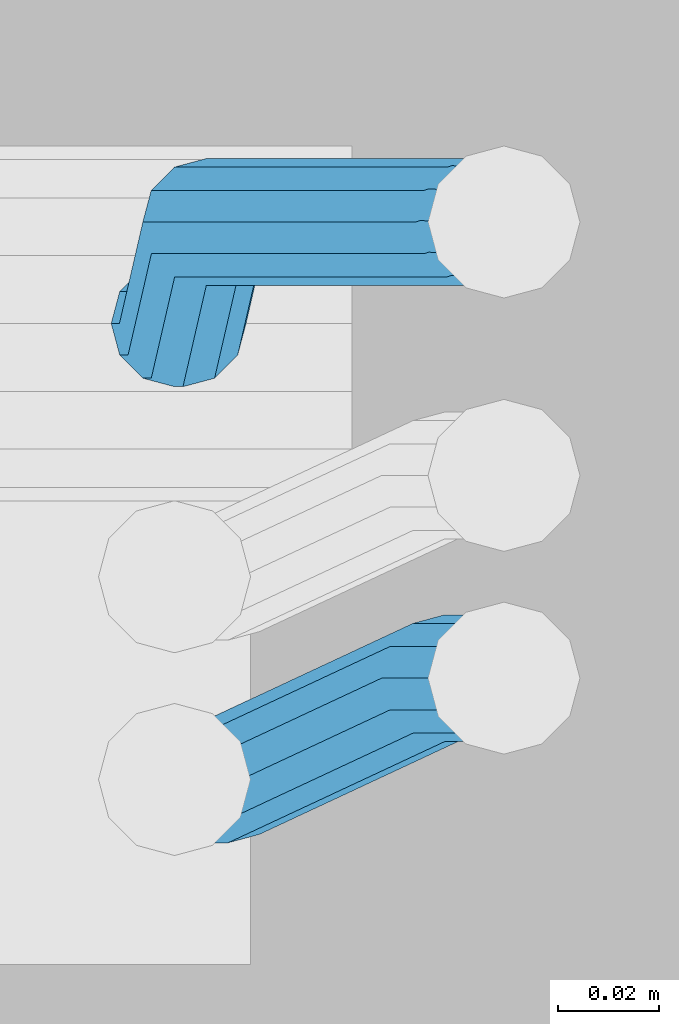
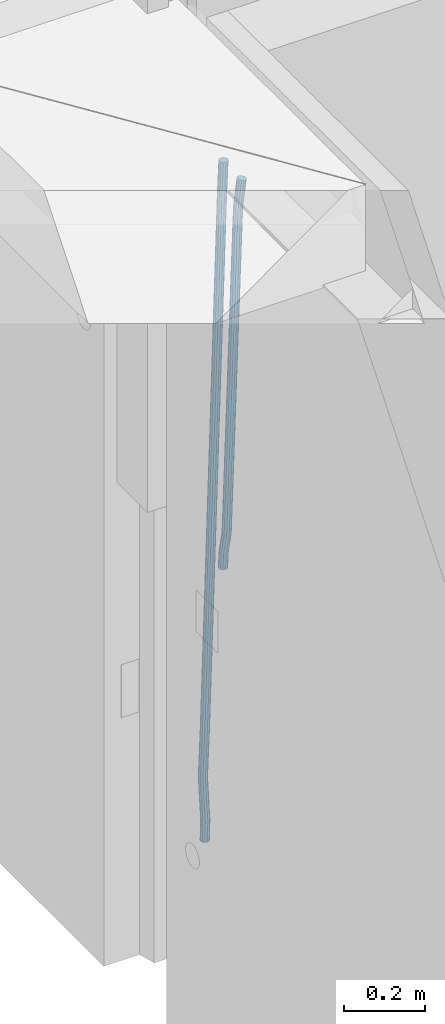
# One storey, part 117 of 341: 2 beams, 1 element without a shape of its own.
"""IFC2X3 building model written with IfcOpenShell, lengths in millimetres."""

from ifc_helpers import new_model, si_unit, frame, origin_with_axes, place, context, subcontext, project, spatial, faceted_brep, material, type_object, element, aggregate, save


model = new_model("IFC2X3")

# Units and contexts
model_context = context("Model", 3, precision=1e-05, world=origin_with_axes())
body_context = subcontext(model_context, "Body", "Model", "MODEL_VIEW")
ifc_project = project(units=[si_unit("LENGTHUNIT", "METRE", prefix="MILLI"), si_unit("AREAUNIT", "SQUARE_METRE"), si_unit("VOLUMEUNIT", "CUBIC_METRE"), si_unit("MASSUNIT", "GRAM", prefix="KILO"), si_unit("TIMEUNIT", "SECOND"), si_unit("PLANEANGLEUNIT", "RADIAN"), si_unit("SOLIDANGLEUNIT", "STERADIAN"), si_unit("THERMODYNAMICTEMPERATUREUNIT", "DEGREE_CELSIUS"), si_unit("LUMINOUSINTENSITYUNIT", "LUMEN")], contexts=[model_context])

# Site, building, storey
site_placement = place(None, origin_with_axes())
site = spatial("IfcSite", under=ifc_project, at=site_placement, CompositionType="ELEMENT")
building_placement = place(site_placement, origin_with_axes())
building = spatial("IfcBuilding", under=site, at=building_placement, CompositionType="ELEMENT")
storey_placement = place(building_placement, origin_with_axes())
storey = spatial("IfcBuildingStorey", under=building, at=storey_placement, Name="5", CompositionType="ELEMENT", Elevation=0.0)

# Assembly, beams
assembly_placement = place(storey_placement, origin_with_axes())
assembly = element("IfcElementAssembly", 1, at=assembly_placement, inside=storey, AssemblyPlace="NOTDEFINED", PredefinedType="REINFORCEMENT_UNIT")
ifc_material = material()
beam_type = type_object("IfcBeamType", Name="D25", PredefinedType="NOTDEFINED")
beam_1_placement = place(assembly_placement, frame((17644.9989431251, 20116.4982803956, 95267.5035525011), z_axis=(0.0, 1.0, 0.0), x_axis=(0.0467115440025518, 0.0, 0.998908420055061)))
beam_1 = element("IfcBeam", 2, at=beam_1_placement, type_object=beam_type, material=ifc_material, Name="JM25", ObjectType="D25", context=body_context, shape_type="Brep", body=[
    faceted_brep([(-7.41420080885291e-08, -12.5, -3.63797880709171e-12), (-6.42030499875546e-08, -10.8253175473074, -6.25000000000364), (48.7743672639481, -10.8253174221936, -6.25), (48.7743672682554, -12.4999998748863, 0.0), (-3.70782800018787e-08, -6.25000000000364, -10.8253175473074), (48.7743672522192, -6.24999987488263, -10.8253175473037), (-1.45519152283669e-11, -3.63797880709171e-12, -12.5), (48.7743672361976, 1.25113729154691e-07, -12.5), (3.70637280866504e-08, 6.25, -10.8253175473074), (48.7743672201614, 6.25000012511737, -10.8253175473037), (6.42030499875546e-08, 10.8253175473001, -6.25000000000364), (48.774367208418, 10.8253176724174, -6.25), (7.41420080885291e-08, 12.4999999999927, 0.0), (48.7743672041252, 12.5000001251174, 0.0), (6.42176019027829e-08, 10.8253175473001, 6.24999999999636), (48.774367208418, 10.8253176724174, 6.25), (3.70928319171071e-08, 6.24999999999636, 10.8253175473037), (48.7743672201614, 6.25000012511737, 10.8253175473037), (1.45519152283669e-11, -3.63797880709171e-12, 12.4999999999964), (48.7743672361976, 1.25113729154691e-07, 12.5), (-3.7049176171422e-08, -6.25000000000364, 10.8253175473001), (48.7743672522192, -6.24999987488263, 10.8253175473037), (-6.41884980723262e-08, -10.8253175473074, 6.25), (48.7743672639481, -10.8253174221936, 6.25), (50.6284132863948, -10.8253174174351, -6.25), (50.7256294211547, -12.4999998698804, 0.0), (50.362813866901, -6.2499998708081, -10.8253175473037), (49.9999983126327, 1.28262399812229e-07, -12.5), (49.6371827583935, 6.25000012732926, -10.8253175473037), (49.3715833388851, 10.8253176739527, -6.25), (49.2743672041252, 12.5000001264016, 0.0), (49.3715833388851, 10.8253176739527, 6.25), (49.6371827583935, 6.25000012732926, 10.8253175473037), (49.9999983126327, 1.28262399812229e-07, 12.5), (50.362813866901, -6.2499998708081, 10.8253175473037), (50.6284132863948, -10.8253174174351, 6.25), (52.4700055286376, -10.6107838149001, -6.25), (52.6637847850943, -12.2742172873113, 0.0), (51.9405907545442, -6.0661990532717, -10.8253175473037), (51.2173967239651, 0.141819180764287, -12.5), (50.494202693415, 6.34983741480755, -10.8253175473037), (49.9647879192926, 10.8944221764359, -6.25), (49.7710086628358, 12.5578556488472, 0.0), (49.9647879192926, 10.8944221764359, 6.25), (50.494202693415, 6.34983741480755, 10.8253175473037), (51.2173967239651, 0.141819180764287, 12.5), (51.9405907545442, -6.0661990532717, 10.8253175473037), (52.4700055286376, -10.6107838149037, 6.25), (100.1682419055, -5.05424733003747, -6.25), (100.362021161956, -6.71768080244692, 0.0), (99.6388271314063, -0.509662568409112, -10.8253175473037), (98.9156331008271, 5.69835566563052, -12.5), (98.192439070277, 11.9063738996665, -10.8253175473037), (97.6630242961546, 16.4509586612985, -6.25), (97.4692450396979, 18.1143921337098, 0.0), (97.6630242961546, 16.4509586612985, 6.25), (98.192439070277, 11.9063738996665, 10.8253175473037), (98.9156331008271, 5.69835566563052, 12.5), (99.6388271314063, -0.509662568409112, 10.8253175473037), (100.1682419055, -5.05424733003747, 6.25), (100.829389846811, -4.97722786481609, -6.25), (100.858662620667, -6.65982528000313, 0.0), (100.613505361369, -0.39611884945225, -10.8253175473037), (100.268855237926, 5.8559973049887, -12.5), (99.8877881987282, 12.1038711239344, -10.8253175473037), (99.5724108491268, 16.6733898631865, -6.25), (99.4072282953421, 18.3401546667665, 0.0), (99.4365010692127, 16.6575572515831, 6.25), (99.6523855546402, 12.0764482362174, 10.8253175473037), (99.9970356780832, 5.82433208178009, 12.5), (100.37810271731, -0.423541737165579, 10.8253175473037), (100.693480066882, -4.99306047642312, 6.25), (101.494850382805, -4.9772278650471, -6.23547852116099), (101.358543616545, -6.65982528017412, 0.0109082521194068), (101.594541309358, -0.396118849792401, -10.8039096771354), (101.63090429295, 5.85599730451395, -12.4702777768798), (101.594195901474, 12.1038711233377, -10.7880808337759), (101.49425211882, 16.6733898625134, -6.2080621602363), (101.357852800793, 18.340154666088, 0.0425659388420172), (101.221546034547, 16.6575572509591, 6.28895271212241), (101.121855107995, 12.0764482357044, 10.8573838680968), (101.085492124403, 5.82433208139992, 12.5237519678412), (101.122200515863, -0.423541737425694, 10.8415550247373), (101.222144298532, -4.99306047660866, 6.26153635119772), (1016.15234243186, -4.97722818425427, 13.7239010304511), (1016.01603566563, -6.65982559938311, 19.9702878037351), (1016.25203335841, -0.396119168995938, 9.15546987447669), (1016.28839634202, 5.85599698530859, 7.48910177473226), (1016.25168795056, 12.1038708041378, 9.17129871783618), (1016.15174416787, 16.6733895433135, 13.7513173913758), (1016.01534484986, 18.3401543468826, 20.0019454904541), (1015.8790380836, 16.6575569317556, 26.2483322637381), (1015.77934715705, 12.0764479165045, 30.8167634197125), (1015.74298417347, 5.82433176219456, 32.4831315194569), (1015.77969256493, -0.423542056632868, 30.8009345763494), (1015.8796363476, -4.99306079580856, 26.2209159028134), (1016.72024271244, -4.97722818445254, 13.7362935788587), (1016.65208128402, -6.65982559960139, 19.984167399125), (1016.77009392806, -0.396119169179656, 9.16677483576495), (1016.7882773379, 5.85599698513579, 7.50001002685531), (1016.76992071191, 12.1038708039559, 9.18260743664359), (1016.71994269331, 16.6733895431171, 13.7637164479929), (1016.65173485172, 18.3401543466607, 20.015832600875), (1016.58357342328, 16.65755693151, 26.2637064211413), (1016.53372220766, 12.0764479162353, 30.833225164235), (1016.51553879784, 5.82433176192717, 32.4999899731447), (1016.53389542381, -0.423542056894803, 30.8173925633564), (1016.58387344243, -4.99306079605594, 26.2362835520071), (1017.28827819017, -4.97722813975997, 13.7362935788587), (1017.28827832255, -6.6598255495519, 19.984167399125), (1017.28827782976, -0.396119128414284, 9.16677483576495), (1017.28827733788, 5.85599702447144, 7.50001002685531), (1017.28827684635, 12.103870844734, 9.18260743664359), (1017.28827648686, 16.6733895878278, 13.7637164479929), (1017.28827635571, 18.3401543967448, 20.015832600875), (1017.28827648809, 16.657556986951, 26.2637064211413), (1017.2882768485, 12.0764479756035, 30.833225164235), (1017.28827734038, 5.8243318227178, 32.4999899731447), (1017.28827783192, -0.423541997544817, 30.8173925633564), (1017.28827819142, -4.99306074063679, 26.2362835520071), (1065.6667756622, -4.97722433367016, 13.7362935788587), (1065.66677579457, -6.65982174345845, 19.984167399125), (1065.6667753018, -0.3961153223172, 9.16677483576495), (1065.66677480991, 5.85600083056488, 7.50001002685531), (1065.66677431838, 12.1038746508275, 9.18260743664359), (1065.66677395887, 16.6733933939249, 13.7637164479929), (1065.66677382775, 18.3401582028346, 20.015832600875), (1065.66677396011, 16.6575607930445, 26.2637064211413), (1065.66677432053, 12.0764517816933, 30.833225164235), (1065.6667748124, 5.82433562881488, 32.4999899731447), (1065.66677530395, -0.423538191451371, 30.8173925633564), (1065.66677566344, -4.99305693454517, 26.2362835520071), (1067.07165110651, -4.97722422314291, 13.7362935788587), (1067.13694763639, -6.65982162779255, 19.984167399125), (1066.89387208481, -0.396115225779795, 9.16677483576495), (1066.6512463166, 5.85600090801745, 7.50001002685531), (1066.40878518049, 12.1038747092061, 9.18260743664359), (1066.23145594214, 16.6733934383519, 13.7637164479929), (1066.16677382775, 18.340158242172, 20.015832600875), (1066.23207035761, 16.6575608375188, 26.2637064211413), (1066.40984937931, 12.0764518401556, 30.833225164235), (1066.65247514757, 5.82433570636204, 32.4999899731447), (1066.89493628364, -0.423538094826654, 30.8173925633564), (1067.07226552199, -4.99305682397062, 26.2362835520071), (1068.47230333716, -4.86837412698696, 13.736334784764), (1068.60269804588, -6.54588751704068, 19.9842150143704), (1068.11728165975, -0.301059828409052, 9.16679859123906), (1067.63276078545, 5.93224720081525, 7.50000996663584), (1067.14856769117, 12.161337376032, 9.18258357686864), (1066.79444152558, 16.7171310152116, 13.7636751818718), (1066.66527010873, 18.3789068918468, 20.0157849856296), (1066.79566481744, 16.7013935018003, 26.263665215236), (1067.15068649485, 12.134079203217, 30.8332014087609), (1067.63520736917, 5.90077217399266, 32.4999900333642), (1068.11940046342, -0.328318001224034, 30.8174164231314), (1068.47352662902, -4.88411164040008, 26.2363248181282), (1142.62319484423, 0.89544508106701, 13.736334784764), (1142.75358955294, -0.782068308983071, 19.9842150143704), (1142.26817316683, 5.4627593796431, 9.16679859123906), (1141.78365229251, 11.6960664088729, 7.50000996663584), (1141.29945919824, 17.9251565840896, 9.18258357686864), (1140.94533303265, 22.4809502232638, 13.7636751818718), (1140.81616161579, 24.1427260999008, 20.0157849856296), (1140.94655632452, 22.4652127098525, 26.263665215236), (1141.30157800192, 17.8978984112746, 30.8332014087609), (1141.78609887623, 11.6645913820466, 32.4999900333642), (1142.27029197049, 5.43550120682994, 30.8174164231314), (1142.6244181361, 0.879707567652076, 26.2363248181282)], [[[0, 1, 2, 3]], [[1, 4, 5, 2]], [[4, 6, 7, 5]], [[6, 8, 9, 7]], [[8, 10, 11, 9]], [[10, 12, 13, 11]], [[12, 14, 15, 13]], [[14, 16, 17, 15]], [[16, 18, 19, 17]], [[18, 20, 21, 19]], [[20, 22, 23, 21]], [[22, 0, 3, 23]], [[22, 20, 18, 16, 14, 12, 10, 8, 6, 4, 1, 0]], [[3, 2, 24, 25]], [[2, 5, 26, 24]], [[5, 7, 27, 26]], [[7, 9, 28, 27]], [[9, 11, 29, 28]], [[11, 13, 30, 29]], [[13, 15, 31, 30]], [[15, 17, 32, 31]], [[17, 19, 33, 32]], [[19, 21, 34, 33]], [[21, 23, 35, 34]], [[23, 3, 25, 35]], [[25, 24, 36, 37]], [[24, 26, 38, 36]], [[26, 27, 39, 38]], [[27, 28, 40, 39]], [[28, 29, 41, 40]], [[29, 30, 42, 41]], [[30, 31, 43, 42]], [[31, 32, 44, 43]], [[32, 33, 45, 44]], [[33, 34, 46, 45]], [[34, 35, 47, 46]], [[35, 25, 37, 47]], [[37, 36, 48, 49]], [[36, 38, 50, 48]], [[38, 39, 51, 50]], [[39, 40, 52, 51]], [[40, 41, 53, 52]], [[41, 42, 54, 53]], [[42, 43, 55, 54]], [[43, 44, 56, 55]], [[44, 45, 57, 56]], [[45, 46, 58, 57]], [[46, 47, 59, 58]], [[47, 37, 49, 59]], [[49, 48, 60, 61]], [[48, 50, 62, 60]], [[50, 51, 63, 62]], [[51, 52, 64, 63]], [[52, 53, 65, 64]], [[53, 54, 66, 65]], [[54, 55, 67, 66]], [[55, 56, 68, 67]], [[56, 57, 69, 68]], [[57, 58, 70, 69]], [[58, 59, 71, 70]], [[59, 49, 61, 71]], [[61, 60, 72, 73]], [[60, 62, 74, 72]], [[62, 63, 75, 74]], [[63, 64, 76, 75]], [[64, 65, 77, 76]], [[65, 66, 78, 77]], [[66, 67, 79, 78]], [[67, 68, 80, 79]], [[68, 69, 81, 80]], [[69, 70, 82, 81]], [[70, 71, 83, 82]], [[71, 61, 73, 83]], [[73, 72, 84, 85]], [[72, 74, 86, 84]], [[74, 75, 87, 86]], [[75, 76, 88, 87]], [[76, 77, 89, 88]], [[77, 78, 90, 89]], [[78, 79, 91, 90]], [[79, 80, 92, 91]], [[80, 81, 93, 92]], [[81, 82, 94, 93]], [[82, 83, 95, 94]], [[83, 73, 85, 95]], [[85, 84, 96, 97]], [[84, 86, 98, 96]], [[86, 87, 99, 98]], [[87, 88, 100, 99]], [[88, 89, 101, 100]], [[89, 90, 102, 101]], [[90, 91, 103, 102]], [[91, 92, 104, 103]], [[92, 93, 105, 104]], [[93, 94, 106, 105]], [[94, 95, 107, 106]], [[95, 85, 97, 107]], [[97, 96, 108, 109]], [[96, 98, 110, 108]], [[98, 99, 111, 110]], [[99, 100, 112, 111]], [[100, 101, 113, 112]], [[101, 102, 114, 113]], [[102, 103, 115, 114]], [[103, 104, 116, 115]], [[104, 105, 117, 116]], [[105, 106, 118, 117]], [[106, 107, 119, 118]], [[107, 97, 109, 119]], [[109, 108, 120, 121]], [[108, 110, 122, 120]], [[110, 111, 123, 122]], [[111, 112, 124, 123]], [[112, 113, 125, 124]], [[113, 114, 126, 125]], [[114, 115, 127, 126]], [[115, 116, 128, 127]], [[116, 117, 129, 128]], [[117, 118, 130, 129]], [[118, 119, 131, 130]], [[119, 109, 121, 131]], [[121, 120, 132, 133]], [[120, 122, 134, 132]], [[122, 123, 135, 134]], [[123, 124, 136, 135]], [[124, 125, 137, 136]], [[125, 126, 138, 137]], [[126, 127, 139, 138]], [[127, 128, 140, 139]], [[128, 129, 141, 140]], [[129, 130, 142, 141]], [[130, 131, 143, 142]], [[131, 121, 133, 143]], [[133, 132, 144, 145]], [[132, 134, 146, 144]], [[134, 135, 147, 146]], [[135, 136, 148, 147]], [[136, 137, 149, 148]], [[137, 138, 150, 149]], [[138, 139, 151, 150]], [[139, 140, 152, 151]], [[140, 141, 153, 152]], [[141, 142, 154, 153]], [[142, 143, 155, 154]], [[143, 133, 145, 155]], [[145, 144, 156, 157]], [[144, 146, 158, 156]], [[146, 147, 159, 158]], [[147, 148, 160, 159]], [[148, 149, 161, 160]], [[149, 150, 162, 161]], [[150, 151, 163, 162]], [[151, 152, 164, 163]], [[152, 153, 165, 164]], [[153, 154, 166, 165]], [[154, 155, 167, 166]], [[155, 145, 157, 167]], [[158, 159, 160, 161, 162, 163, 164, 165, 166, 167, 157, 156]]]),
])
beam_2_placement = place(assembly_placement, frame((17645.0, 20206.4982799665, 94390.0), z_axis=(0.999642804629538, 0.000205762999925497, -0.0267249099901003), x_axis=(0.0267249109941254, -4.30000210532798e-08, 0.999642825779465)))
beam_2 = element("IfcBeam", 3, at=beam_2_placement, type_object=beam_type, material=ifc_material, Name="JM25", ObjectType="D25", context=body_context, shape_type="Brep", body=[
    faceted_brep([(-7.41420080885291e-08, -12.5, -3.63797880709171e-12), (-6.42030499875546e-08, -10.8253175473074, -6.25000000000364), (59.4220778053423, -10.8253175324608, -6.25000005319089), (59.4220778086747, -12.4999999851534, -5.3194526117295e-08), (-3.70782800018787e-08, -6.25000000000364, -10.8253175473074), (59.4220778020681, -6.24999998515341, -10.8253176004946), (-1.45519152283669e-11, -3.63797880709171e-12, -12.5), (59.4220777997252, 1.48465915117413e-08, -12.5000000531927), (3.70637280866504e-08, 6.25, -10.8253175473074), (59.422077798954, 6.25000001485023, -10.8253176004982), (6.42030499875546e-08, 10.8253175473001, -6.25000000000364), (59.4220777999435, 10.8253175621539, -6.25000005319089), (7.41420080885291e-08, 12.4999999999927, 0.0), (59.4220778024173, 12.5000000148466, -5.31908881384879e-08), (6.42176019027829e-08, 10.8253175473001, 6.24999999999636), (59.4220778057497, 10.8253175621576, 6.24999994680911), (3.70928319171071e-08, 6.24999999999636, 10.8253175473037), (59.4220778090239, 6.25000001485023, 10.8253174941128), (1.45519152283669e-11, -3.63797880709171e-12, 12.4999999999964), (59.4220778113668, 1.48465915117413e-08, 12.4999999468128), (-3.7049176171422e-08, -6.25000000000364, 10.8253175473001), (59.4220778121526, -6.24999998515705, 10.8253174941183), (-6.41884980723262e-08, -10.8253175473074, 6.25), (59.422077811163, -10.8253175324571, 6.24999994680547), (60.1059015733626, -10.8253175322861, -6.25000005380571), (59.9220778086747, -12.4999999850261, -5.36383595317602e-08), (60.5270973313018, -6.24999998487692, -10.8253176014878), (61.0728060192778, 1.52613210957497e-08, -12.5000000546715), (61.5968054350378, 6.25000001539229, -10.8253176024446), (61.9586903583258, 10.825317562787, -6.25000005546281), (62.0614940161613, 12.5000000155051, -5.55555743630975e-08), (61.8776702514588, 10.8253175627651, 6.24999994460995), (61.4564744935342, 6.25000001535955, 10.8253174922938), (60.9107658055436, 1.52213033288717e-08, 12.4999999454776), (60.3867663897981, -6.2499999849133, 10.8253174932506), (60.0248814664956, -10.825317532308, 6.24999994626887), (60.7797257564671, -10.9415004936782, -6.24120031120765), (60.4147662867617, -12.5849509379113, 0.00643416450657242), (61.6159581115353, -6.43774490879878, -10.8110977280703), (62.6993955677171, -0.280461855141766, -12.4787577637399), (63.739731933616, 5.88050964549984, -10.7973322583985), (64.4582099200925, 10.3943422549237, -6.21735781835014), (64.6623139309086, 12.0515581706859, 0.03396510384664), (64.2973544612178, 10.4081077264564, 6.28159957956086), (63.461122106135, 5.90435214157333, 10.8514969964235), (62.3776846499532, -0.252930912083684, 12.5191570320894), (61.3373482840689, -6.41390241272165, 10.8377315267553), (60.6188702975924, -10.9277350221564, 6.25775708670699), (173.678050556482, -30.407797550004, -4.76681541592006), (173.313091086762, -32.0512479942336, 1.4808190597978), (174.514282911536, -25.9040419651246, -9.33671283278272), (175.597720367718, -19.7467589114676, -11.0043728684504), (176.638056733602, -13.585787410826, -9.32294736311087), (177.356534720093, -9.0719548013949, -4.74297292306073), (177.560638730924, -7.41473888563996, 1.50834999913423), (177.195679261218, -9.05818932986585, 7.75598447485027), (176.35944690615, -13.5619449147489, 12.3258818917166), (175.276009449968, -19.7192279684059, 13.9935419273806), (174.235673084069, -25.8801994690475, 12.3121164220465), (173.517195097593, -30.3940320784823, 7.73214198199094), (176.138237106381, -30.8319909317906, -4.73468684452382), (175.913853754129, -32.499679968274, 1.51478347157899), (176.589132212815, -26.2617942428296, -9.30961653639861), (177.145722093832, -20.0136704134529, -10.98415688768), (177.658868940271, -13.7617991779516, -9.30961616354944), (177.991075469021, -9.18136438506554, -4.73468619872801), (178.053327209011, -7.49968983852159, 1.5147842172828), (177.828943856759, -9.16737887500858, 7.76425453338925), (177.37804875031, -13.7375755639696, 12.3391842252604), (176.821458869294, -19.9856993933463, 14.0137245765418), (176.308312022869, -26.237570628844, 12.3391838524112), (175.976105494119, -30.8180054217337, 7.76425388758798), (178.634722048839, -30.8318743800774, -4.70223538057326), (178.552989161486, -32.4996730848652, 1.54907076560085), (178.694593853957, -26.2615981169292, -9.28219734144659), (178.71656197503, -20.0134461293128, -10.9636180082289), (178.694740071747, -13.7616056964944, -9.29596207112627), (178.634975305482, -9.18125241366579, -4.72607659172718), (178.553281597095, -7.49968824400275, 1.52154130624513), (178.471548709742, -9.16748694879061, 7.7728474524265), (178.411676904623, -13.7377632119424, 12.3528094132944), (178.389708783536, -19.9859151995588, 14.0342300800785), (178.411530686833, -26.23775563237, 12.3665741429741), (178.471295453099, -30.8181089152022, 7.79668866358043), (319.488626215083, -30.8314939674237, -2.86053540860667), (319.406893327759, -32.499292672208, 3.39077073757289), (319.548498020216, -26.261217704272, -7.44049736947818), (319.570466141289, -20.0130657166519, -9.12191803626411), (319.548644237992, -13.7612252838408, -7.45426209915786), (319.488879471741, -9.18087200101581, -2.88437661976423), (319.407185763353, -7.4993078313455, 3.36324127821172), (319.325452876015, -9.167106536137, 9.61454742438946), (319.265581070882, -13.7373827992851, 14.1945093852592), (319.243612949809, -19.9855347868979, 15.8759300520433), (319.265434853078, -26.2373752197163, 14.2082741149388), (319.325199619343, -30.8177285025449, 9.63838863554338), (320.017443228702, -30.8314925392151, -2.85362099409576), (319.964532372032, -32.4992911661575, 3.39806200733256), (320.056202037245, -26.2612163330814, -7.43385901266629), (320.070423406214, -20.013064366387, -9.11538097016819), (320.056296731302, -13.7612239127957, -7.44762441603234), (320.01760724363, -9.18087057304729, -2.87746337211138), (319.964721760145, -7.4993063255788, 3.37053120060227), (319.91181090349, -9.16710495252482, 9.62221420203059), (319.873052094961, -13.7373811586476, 14.2024522205975), (319.858830725978, -19.9855331253457, 15.8839741781048), (319.87295740089, -26.2373735789442, 14.2162176239653), (319.911646888577, -30.8177269186926, 9.64605658004257), (320.546301518712, -30.8314921215424, -2.85158332608989), (320.522214942423, -32.4992907257256, 3.40021073403295), (320.563945682734, -26.2612159320888, -7.431902698474), (320.570419694937, -20.0130639715098, -9.1134545062032), (320.563988849026, -13.7612235118395, -7.44566830037184), (320.546376284925, -9.1808701554437, -2.87542604797454), (320.522301275021, -7.49930588522329, 3.37267953023547), (320.498214698731, -9.16710448940648, 9.62447359036014), (320.480570534695, -13.7373806788601, 14.2047929627461), (320.474096522506, -19.9855326394354, 15.8863447704753), (320.480527368418, -26.2373730991094, 14.2185585646439), (320.498139932504, -30.8177264555052, 9.64831631225024), (1894.35323904471, -30.8302491939103, 3.21222639639745), (1894.32915246842, -32.4980477980898, 9.46402045652394), (1894.37088320871, -26.2599730044531, -1.36809297598302), (1894.37735722095, -20.0118210438777, -3.04964478371585), (1894.37092637502, -13.7599805842037, -1.38185857788449), (1894.35331381093, -9.1796272278043, 3.18838367451281), (1894.32923880102, -7.4980629575839, 9.43648925272464), (1894.30515222471, -9.16586156176709, 15.6882833128511), (1894.2875080607, -13.7361377512207, 20.2686026852371), (1894.28103404849, -19.9842897117996, 21.9501544929644), (1894.2874648944, -26.2361301714736, 20.2823682871331), (1894.30507745848, -30.8164835278658, 15.7121260347358), (1894.91223858956, -30.8302487524343, 3.21438019734705), (1894.84772318714, -32.4980473885444, 9.46601848696628), (1894.98133310449, -26.2599725223481, -1.36574093906893), (1895.03649291246, -20.0118205233157, -3.04710516254454), (1895.06293798747, -13.7599800376811, -1.37919228721876), (1895.05358239301, -9.17962667476604, 3.19108177892304), (1895.01093295308, -7.49806241920669, 9.43911579066662), (1894.94641755069, -9.16586105532406, 15.6907540802767), (1894.87732303573, -13.7361372854102, 20.2708752166945), (1894.82216322777, -19.984289284439, 21.9522394401702), (1894.79571815276, -26.2361297700772, 20.284326564848), (1894.80507374721, -30.8164831329887, 15.7140524987026), (1895.47114527243, -30.837537004496, 3.22181869265842), (1895.36620776, -32.5048085284143, 9.47291900396158), (1895.59168159126, -26.267931585553, -1.35761780421126), (1895.69551910722, -20.0204143533228, -3.03833417552232), (1895.75483464175, -13.7690025048832, -1.36998382688762), (1895.75373464527, -9.18875679657504, 3.20040011310266), (1895.69251386097, -7.50695036707475, 9.44818695861068), (1895.58757634854, -9.17422189099307, 15.699287269912), (1895.4670400297, -13.7438273099324, 20.2787237667835), (1895.36320251375, -19.9913445421626, 21.9594401380946), (1895.30388697921, -26.2427563905985, 20.2910897894599), (1895.30498697569, -30.823002098914, 15.720705849466), (1917.25744196717, -31.1216345590001, 3.51177275974987), (1917.15250445475, -32.788906082922, 9.7628730710494), (1917.37797828601, -26.5520291400608, -1.0676637371198), (1917.48181580196, -20.3045119078306, -2.7483801084345), (1917.5411313365, -14.0531000593946, -1.08002975979252), (1917.54003134, -9.47285435107915, 3.49035418019412), (1917.47881055571, -7.7910479215825, 9.73814102570577), (1917.37387304328, -9.45831944550082, 15.9892413370071), (1917.25333672446, -14.0279248644365, 20.5686778338786), (1917.14949920849, -20.2754420966667, 22.2493942051933), (1917.09018367396, -26.5268539451099, 20.5810438565477), (1917.09128367042, -31.1070996534218, 16.0106599165647), (1917.94316974688, -31.1305765828838, 3.52089911846269), (1917.85264237775, -32.7980360178735, 9.77219121452072), (1918.02633208608, -26.5604837999635, -1.05903478912296), (1918.0798461137, -20.3123103396429, -2.7404209163069), (1918.08937278928, -14.0602492347753, -1.07273320814602), (1918.05235944779, -9.47953520944429, 3.49717276072806), (1917.9787237842, -7.79756688750422, 9.74479437647096), (1917.88819641506, -9.46502632249758, 15.9960864725308), (1917.80503407588, -14.0351191054142, 20.5760203801128), (1917.75152004823, -20.2832925657385, 22.257406507304), (1917.74199337266, -26.5353536706025, 20.5897187991395), (1917.77900671415, -31.1160676959298, 16.0198128302654), (1918.62895550129, -31.1285475281402, 3.52982218347461), (1918.55283939735, -32.795947999115, 9.78130547352521), (1918.67474087057, -26.5585779185749, -1.05060823136955), (1918.67792735249, -20.3105588367471, -2.73266314035027), (1918.63766113177, -14.0586419499232, -1.06563728897891), (1918.56473150974, -9.47802333907384, 3.50379109209644), (1918.47867991975, -7.79607606181162, 9.75124735830832), (1918.40256381579, -9.46347653279008, 16.0027306483644), (1918.35677844651, -14.0334461423481, 20.5831610632049), (1918.35359196461, -20.2814652241759, 22.2652159721838), (1918.39385818531, -26.5333821109998, 20.5981901208143), (1918.46678780734, -31.1140007218564, 16.0287617397316), (2018.62971518922, -30.8303462840922, 4.82693655916046), (2018.5535990853, -32.4977467550671, 11.0784198492183), (2018.67550055851, -26.2603766745233, 0.246506144323575), (2018.67868704045, -20.0123575926991, -1.43554876465714), (2018.63842081973, -13.7604407058789, 0.231477086710584), (2018.5654911977, -9.17982209502588, 4.80090546778956), (2018.47943960771, -7.49787481776366, 11.0483617339996), (2018.40332350375, -9.16527528874212, 17.2998450240593), (2018.35753813446, -13.7352448983038, 21.880275438898), (2018.35435165254, -19.9832639801316, 23.5623303478787), (2018.39461787326, -26.2351808669555, 21.8953044965092), (2018.46754749528, -30.8157994778048, 17.3258761154248)], [[[0, 1, 2, 3]], [[1, 4, 5, 2]], [[4, 6, 7, 5]], [[6, 8, 9, 7]], [[8, 10, 11, 9]], [[10, 12, 13, 11]], [[12, 14, 15, 13]], [[14, 16, 17, 15]], [[16, 18, 19, 17]], [[18, 20, 21, 19]], [[20, 22, 23, 21]], [[22, 0, 3, 23]], [[22, 20, 18, 16, 14, 12, 10, 8, 6, 4, 1, 0]], [[3, 2, 24, 25]], [[2, 5, 26, 24]], [[5, 7, 27, 26]], [[7, 9, 28, 27]], [[9, 11, 29, 28]], [[11, 13, 30, 29]], [[13, 15, 31, 30]], [[15, 17, 32, 31]], [[17, 19, 33, 32]], [[19, 21, 34, 33]], [[21, 23, 35, 34]], [[23, 3, 25, 35]], [[25, 24, 36, 37]], [[24, 26, 38, 36]], [[26, 27, 39, 38]], [[27, 28, 40, 39]], [[28, 29, 41, 40]], [[29, 30, 42, 41]], [[30, 31, 43, 42]], [[31, 32, 44, 43]], [[32, 33, 45, 44]], [[33, 34, 46, 45]], [[34, 35, 47, 46]], [[35, 25, 37, 47]], [[37, 36, 48, 49]], [[36, 38, 50, 48]], [[38, 39, 51, 50]], [[39, 40, 52, 51]], [[40, 41, 53, 52]], [[41, 42, 54, 53]], [[42, 43, 55, 54]], [[43, 44, 56, 55]], [[44, 45, 57, 56]], [[45, 46, 58, 57]], [[46, 47, 59, 58]], [[47, 37, 49, 59]], [[49, 48, 60, 61]], [[48, 50, 62, 60]], [[50, 51, 63, 62]], [[51, 52, 64, 63]], [[52, 53, 65, 64]], [[53, 54, 66, 65]], [[54, 55, 67, 66]], [[55, 56, 68, 67]], [[56, 57, 69, 68]], [[57, 58, 70, 69]], [[58, 59, 71, 70]], [[59, 49, 61, 71]], [[61, 60, 72, 73]], [[60, 62, 74, 72]], [[62, 63, 75, 74]], [[63, 64, 76, 75]], [[64, 65, 77, 76]], [[65, 66, 78, 77]], [[66, 67, 79, 78]], [[67, 68, 80, 79]], [[68, 69, 81, 80]], [[69, 70, 82, 81]], [[70, 71, 83, 82]], [[71, 61, 73, 83]], [[73, 72, 84, 85]], [[72, 74, 86, 84]], [[74, 75, 87, 86]], [[75, 76, 88, 87]], [[76, 77, 89, 88]], [[77, 78, 90, 89]], [[78, 79, 91, 90]], [[79, 80, 92, 91]], [[80, 81, 93, 92]], [[81, 82, 94, 93]], [[82, 83, 95, 94]], [[83, 73, 85, 95]], [[85, 84, 96, 97]], [[84, 86, 98, 96]], [[86, 87, 99, 98]], [[87, 88, 100, 99]], [[88, 89, 101, 100]], [[89, 90, 102, 101]], [[90, 91, 103, 102]], [[91, 92, 104, 103]], [[92, 93, 105, 104]], [[93, 94, 106, 105]], [[94, 95, 107, 106]], [[95, 85, 97, 107]], [[97, 96, 108, 109]], [[96, 98, 110, 108]], [[98, 99, 111, 110]], [[99, 100, 112, 111]], [[100, 101, 113, 112]], [[101, 102, 114, 113]], [[102, 103, 115, 114]], [[103, 104, 116, 115]], [[104, 105, 117, 116]], [[105, 106, 118, 117]], [[106, 107, 119, 118]], [[107, 97, 109, 119]], [[109, 108, 120, 121]], [[108, 110, 122, 120]], [[110, 111, 123, 122]], [[111, 112, 124, 123]], [[112, 113, 125, 124]], [[113, 114, 126, 125]], [[114, 115, 127, 126]], [[115, 116, 128, 127]], [[116, 117, 129, 128]], [[117, 118, 130, 129]], [[118, 119, 131, 130]], [[119, 109, 121, 131]], [[121, 120, 132, 133]], [[120, 122, 134, 132]], [[122, 123, 135, 134]], [[123, 124, 136, 135]], [[124, 125, 137, 136]], [[125, 126, 138, 137]], [[126, 127, 139, 138]], [[127, 128, 140, 139]], [[128, 129, 141, 140]], [[129, 130, 142, 141]], [[130, 131, 143, 142]], [[131, 121, 133, 143]], [[133, 132, 144, 145]], [[132, 134, 146, 144]], [[134, 135, 147, 146]], [[135, 136, 148, 147]], [[136, 137, 149, 148]], [[137, 138, 150, 149]], [[138, 139, 151, 150]], [[139, 140, 152, 151]], [[140, 141, 153, 152]], [[141, 142, 154, 153]], [[142, 143, 155, 154]], [[143, 133, 145, 155]], [[145, 144, 156, 157]], [[144, 146, 158, 156]], [[146, 147, 159, 158]], [[147, 148, 160, 159]], [[148, 149, 161, 160]], [[149, 150, 162, 161]], [[150, 151, 163, 162]], [[151, 152, 164, 163]], [[152, 153, 165, 164]], [[153, 154, 166, 165]], [[154, 155, 167, 166]], [[155, 145, 157, 167]], [[157, 156, 168, 169]], [[156, 158, 170, 168]], [[158, 159, 171, 170]], [[159, 160, 172, 171]], [[160, 161, 173, 172]], [[161, 162, 174, 173]], [[162, 163, 175, 174]], [[163, 164, 176, 175]], [[164, 165, 177, 176]], [[165, 166, 178, 177]], [[166, 167, 179, 178]], [[167, 157, 169, 179]], [[169, 168, 180, 181]], [[168, 170, 182, 180]], [[170, 171, 183, 182]], [[171, 172, 184, 183]], [[172, 173, 185, 184]], [[173, 174, 186, 185]], [[174, 175, 187, 186]], [[175, 176, 188, 187]], [[176, 177, 189, 188]], [[177, 178, 190, 189]], [[178, 179, 191, 190]], [[179, 169, 181, 191]], [[181, 180, 192, 193]], [[180, 182, 194, 192]], [[182, 183, 195, 194]], [[183, 184, 196, 195]], [[184, 185, 197, 196]], [[185, 186, 198, 197]], [[186, 187, 199, 198]], [[187, 188, 200, 199]], [[188, 189, 201, 200]], [[189, 190, 202, 201]], [[190, 191, 203, 202]], [[191, 181, 193, 203]], [[194, 195, 196, 197, 198, 199, 200, 201, 202, 203, 193, 192]]]),
])
aggregate(assembly, [beam_1, beam_2])

save(model, "model.ifc")
